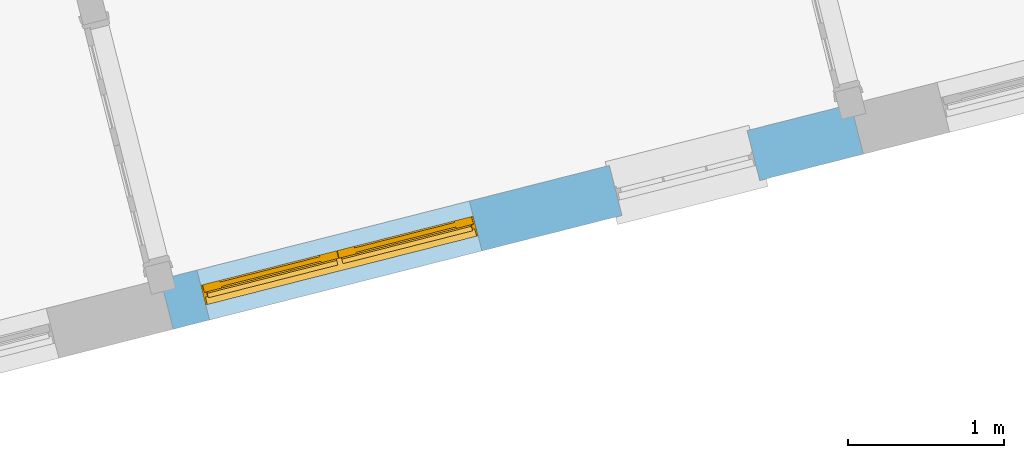
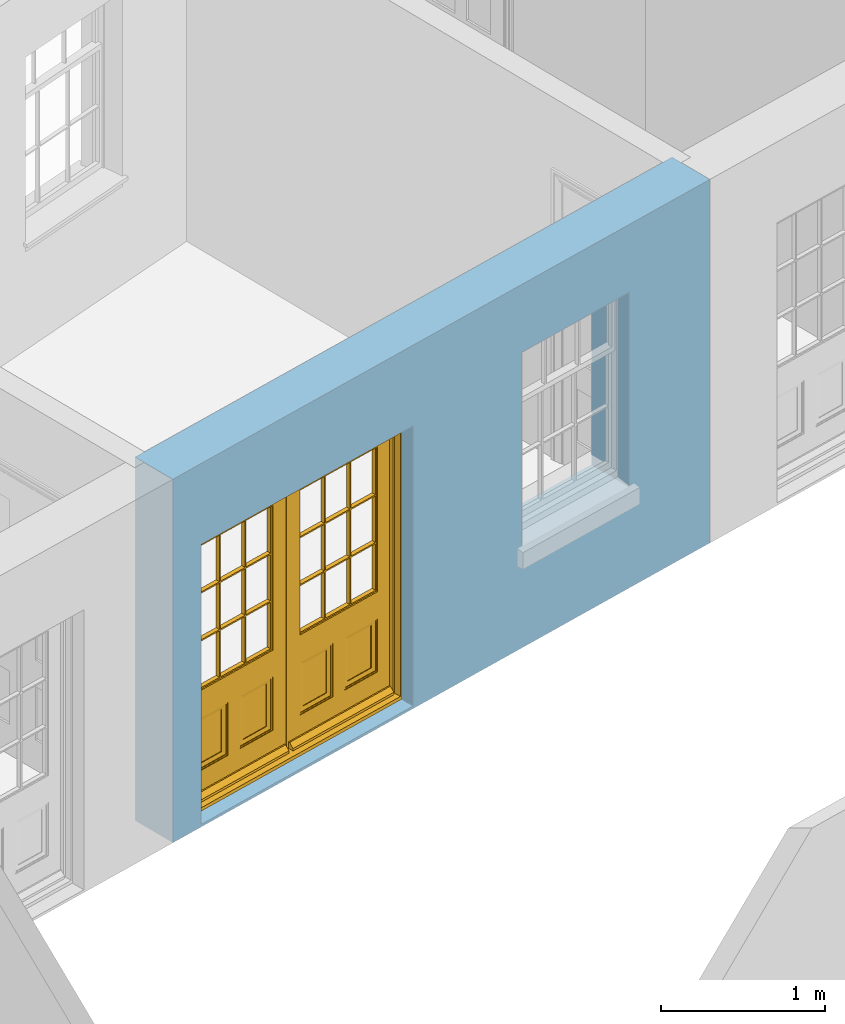
# One storey, part 3 of 15: 1 door, 2 openings, plus 1 element that does not belong to this part.
"""IFC2X3 building model written with IfcOpenShell, lengths in metres."""

from ifc_helpers import new_model, si_unit, frame, origin, place, context, subcontext, project, spatial, polyline, outline, extrude, faceted_brep, material, layer, layer_set, layer_usage, element, fill, save


model = new_model("IFC2X3")

# Units and contexts
model_context = context("Model", 3, world=origin())
body_context = subcontext(model_context, "Body", "Model", "MODEL_VIEW")
ifc_project = project(units=[si_unit("PLANEANGLEUNIT", "RADIAN"), si_unit("MASSUNIT", "GRAM", prefix="KILO"), si_unit("FORCEUNIT", "NEWTON", prefix="KILO"), si_unit("LENGTHUNIT", "METRE")], contexts=[model_context])

# Site, building, storey
site_placement = place(None, origin())
site = spatial("IfcSite", under=ifc_project, at=site_placement, CompositionType="ELEMENT")
building_placement = place(None, origin())
building = spatial("IfcBuilding", under=site, at=building_placement, Name="Building plot-13", CompositionType="ELEMENT")
storey_placement = place(None, frame((0.0, 0.0, 4.0)))
storey = spatial("IfcBuildingStorey", under=building, at=storey_placement, Name="Floor 0", CompositionType="ELEMENT", Elevation=4.0)

# Wall, openings, door
ifc_material = material(Name="Masonry")
ifc_layer = layer(ifc_material, 0.33, ventilated=False)
ifc_layer_set = layer_set([ifc_layer], Name="My Wall")
ifc_layer_usage = layer_usage(ifc_layer_set, "AXIS2", "NEGATIVE", 0.08)
wall_placement = place(storey_placement, origin())
wall = element("IfcWallStandardCase", 1, at=wall_placement, inside=storey, material=ifc_layer_usage, Name="exterior", context=body_context, shape_type="SweptSolid", body=[
    extrude(outline(polyline([(66.7491610907744, 43.8925759474061), (66.8302893451402, 43.5727037755256), (71.2509007169492, 44.6938906600119), (71.1697724625834, 45.0137628318924), (66.7491610907744, 43.8925759474061)])), origin(), (0.0, 0.0, 1.0), 2.7),
])
opening_1_placement = place(storey_placement, frame((0.0, 0.0, 0.0199999999999996)))
opening_1 = element("IfcOpeningElement", 2, at=opening_1_placement, cuts=wall, Name="Opening", ObjectType="Opening", context=body_context, shape_type="SweptSolid", body=[
    extrude(outline(polyline([(67.0630635375092, 43.631741621104), (68.8078208386756, 44.0742593721904), (68.7266925843098, 44.3941315440709), (66.9819352831434, 43.9516137929845), (67.0630635375092, 43.631741621104)])), origin(), (0.0, 0.0, 1.0), 2.08),
])
opening_2_placement = place(storey_placement, frame((0.0, 0.0, 0.75)))
element("IfcOpeningElement", 3, at=opening_2_placement, cuts=wall, Name="Opening", ObjectType="Opening", context=body_context, shape_type="SweptSolid", body=[
    extrude(outline(polyline([(69.7047120006465, 44.3017352851435), (70.5867837473473, 44.5254525926372), (70.5056554929815, 44.8453247645177), (69.6235837462807, 44.621607457024), (69.7047120006465, 44.3017352851435)])), origin(), (0.0, 0.0, 1.0), 1.445),
])
door_placement = place(storey_placement, frame((67.0016027387473, 43.8740690240438, 0.0199999999999996), z_axis=(0.0, 0.0, 1.0), x_axis=(1.7447573011664, 0.442517751086321, 0.0)))
door = element("IfcDoor", 4, at=door_placement, inside=storey, Name="living outside door", OverallHeight=2.08, OverallWidth=1.8, context=body_context, shape_type="Brep", held_by="IfcProductRepresentation", body=[
    faceted_brep([(0.545, -0.055, 0.265), (0.745, -0.055, 0.265), (0.745, -0.05, 0.265), (0.545, -0.05, 0.265), (0.745, -0.05, 0.58), (0.545, -0.05, 0.58), (0.545, -0.055, 0.58), (0.515, -0.06, 0.235), (0.775, -0.06, 0.235), (0.745, -0.055, 0.58), (0.515, -0.06, 0.61), (0.515, -0.065, 0.235), (0.775, -0.065, 0.235), (0.775, -0.06, 0.61), (0.515, -0.065, 0.61), (0.785, -0.065, 0.225), (0.505, -0.065, 0.225), (0.775, -0.065, 0.61), (0.505, -0.065, 0.62), (0.785, -0.065, 0.62), (0.505, -0.07, 0.225), (0.785, -0.07, 0.225), (0.505, -0.07, 0.62), (0.785, -0.07, 0.62), (0.883, -0.07, 0.075), (0.898, -0.07, 0.075), (0.405, -0.07, 0.62), (0.405, -0.07, 0.225), (0.027, -0.07, 0.075), (0.785, -0.07, 0.82), (0.125, -0.07, 0.82), (0.405, -0.065, 0.62), (0.405, -0.065, 0.225), (0.898, -0.07, 2.068), (0.027, -0.08, 0.075), (0.883, -0.08, 0.075), (0.125, -0.07, 0.225), (0.012, -0.07, 0.075), (0.785, -0.06, 0.82), (0.125, -0.06, 0.82), (0.125, -0.07, 0.62), (0.125, -0.065, 0.62), (0.395, -0.065, 0.61), (0.395, -0.065, 0.235), (0.125, -0.065, 0.225), (0.785, -0.07, 1.895), (0.027, -0.11, 0.045), (0.883, -0.11, 0.045), (0.558333, -0.06, 0.83), (0.351667, -0.06, 0.83), (0.125, -0.07, 1.895), (0.125, -0.06, 1.895), (0.785, -0.06, 1.895), (0.012, -0.07, 2.068), (0.135, -0.065, 0.61), (0.395, -0.06, 0.61), (0.395, -0.06, 0.235), (0.135, -0.065, 0.235), (0.027, -0.11, 0.027), (0.883, -0.11, 0.027), (0.568333, -0.06, 0.83), (0.558333, -0.03, 0.83), (0.351667, -0.03, 0.83), (0.341667, -0.06, 0.83), (0.135, -0.06, 1.185), (0.135, -0.06, 1.53), (0.775, -0.06, 1.53), (0.775, -0.06, 1.185), (0.135, -0.06, 0.61), (0.365, -0.055, 0.58), (0.365, -0.055, 0.265), (0.135, -0.06, 0.235), (0.568333, -0.06, 1.175), (0.558333, -0.06, 1.175), (0.775, -0.06, 0.83), (0.558333, -0.03, 1.175), (0.785, -0.03, 0.82), (0.125, -0.03, 0.82), (0.351667, -0.03, 1.175), (0.351667, -0.06, 1.175), (0.341667, -0.06, 1.175), (0.135, -0.06, 0.83), (0.135, -0.06, 1.175), (0.135, -0.03, 1.185), (0.135, -0.03, 1.53), (0.135, -0.06, 1.54), (0.351667, -0.06, 1.885), (0.558333, -0.06, 1.885), (0.775, -0.03, 1.53), (0.775, -0.03, 1.185), (0.775, -0.06, 1.175), (0.775, -0.06, 1.54), (0.165, -0.055, 0.58), (0.365, -0.05, 0.58), (0.365, -0.05, 0.265), (0.165, -0.055, 0.265), (0.568333, -0.03, 0.83), (0.568333, -0.03, 1.175), (0.568333, -0.06, 1.185), (0.558333, -0.06, 1.185), (0.775, -0.03, 0.83), (0.785, -0.02, 0.82), (0.125, -0.02, 0.82), (0.341667, -0.03, 0.83), (0.341667, -0.03, 1.175), (0.351667, -0.06, 1.185), (0.341667, -0.06, 1.185), (0.135, -0.03, 0.83), (0.341667, -0.03, 1.185), (0.125, -0.03, 1.895), (0.341667, -0.03, 1.53), (0.341667, -0.06, 1.53), (0.135, -0.06, 1.885), (0.341667, -0.06, 1.54), (0.341667, -0.06, 1.885), (0.558333, -0.03, 1.885), (0.351667, -0.03, 1.885), (0.568333, -0.06, 1.885), (0.785, -0.03, 1.895), (0.568333, -0.03, 1.185), (0.568333, -0.06, 1.53), (0.568333, -0.03, 1.53), (0.568333, -0.06, 1.54), (0.775, -0.06, 1.885), (0.165, -0.05, 0.58), (0.165, -0.05, 0.265), (0.775, -0.03, 1.175), (0.558333, -0.06, 1.53), (0.351667, -0.03, 1.185), (0.558333, -0.03, 1.185), (0.505, -0.02, 0.62), (0.405, -0.02, 0.62), (0.125, -0.02, 1.895), (0.785, -0.02, 1.895), (0.351667, -0.06, 1.53), (0.135, -0.03, 1.175), (0.135, -0.03, 1.54), (0.341667, -0.03, 1.54), (0.135, -0.03, 1.885), (0.351667, -0.06, 1.54), (0.558333, -0.03, 1.54), (0.558333, -0.06, 1.54), (0.351667, -0.03, 1.54), (0.775, -0.03, 1.54), (0.568333, -0.03, 1.54), (0.775, -0.03, 1.885), (0.558333, -0.03, 1.53), (0.405, -0.02, 0.225), (0.505, -0.02, 0.225), (0.125, -0.02, 0.62), (0.785, -0.02, 0.62), (0.012, -0.02, 2.068), (0.898, -0.02, 2.068), (0.351667, -0.03, 1.53), (0.341667, -0.03, 1.885), (0.568333, -0.03, 1.885), (0.405, -0.025, 0.225), (0.405, -0.025, 0.62), (0.505, -0.025, 0.62), (0.505, -0.025, 0.225), (0.898, -0.02, 0.027), (0.012, -0.02, 0.027), (0.125, -0.025, 0.62), (0.785, -0.025, 0.62), (0.395, -0.025, 0.235), (0.395, -0.025, 0.61), (0.125, -0.02, 0.225), (0.125, -0.025, 0.225), (0.515, -0.025, 0.61), (0.515, -0.025, 0.235), (0.785, -0.02, 0.225), (0.785, -0.025, 0.225), (0.135, -0.025, 0.61), (0.775, -0.025, 0.61), (0.135, -0.025, 0.235), (0.395, -0.03, 0.235), (0.395, -0.03, 0.61), (0.515, -0.03, 0.61), (0.515, -0.03, 0.235), (0.775, -0.025, 0.235), (0.135, -0.03, 0.61), (0.775, -0.03, 0.61), (0.135, -0.03, 0.235), (0.365, -0.035, 0.265), (0.365, -0.035, 0.58), (0.545, -0.035, 0.58), (0.545, -0.035, 0.265), (0.775, -0.03, 0.235), (0.165, -0.035, 0.58), (0.745, -0.035, 0.58), (0.165, -0.035, 0.265), (0.365, -0.04, 0.58), (0.365, -0.04, 0.265), (0.545, -0.04, 0.58), (0.545, -0.04, 0.265), (0.745, -0.035, 0.265), (0.165, -0.04, 0.58), (0.745, -0.04, 0.58), (0.165, -0.04, 0.265), (0.745, -0.04, 0.265), (1.775, -0.072, 0.025), (0.025, -0.072, 0.025), (0.025, -0.1, 0.025), (1.775, -0.1, 0.025), (1.79, -0.02, 0.025), (0.01, -0.02, 0.025), (1.79, -0.072, 0.025), (1.8, -0.02, 0.0), (0.0, -0.02, 0.0), (0.01, -0.072, 0.025), (1.79, -0.072, 2.07), (1.79, -0.02, 2.07), (1.775, -0.072, 2.055), (1.8, -0.02, 2.08), (0.01, -0.02, 2.07), (0.0, -0.02, 2.08), (0.01, -0.072, 2.07), (0.025, -0.072, 2.055), (0.0, -0.15, 2.08), (1.8, -0.15, 2.08), (0.01, -0.15, 2.07), (1.79, -0.15, 2.07), (0.01, -0.1, 2.07), (1.79, -0.1, 2.07), (0.0, -0.15, 0.0), (1.8, -0.15, 0.0), (0.01, -0.15, 0.025), (1.79, -0.15, 0.025), (0.01, -0.1, 0.025), (0.025, -0.1, 2.055), (1.79, -0.1, 0.025), (1.775, -0.1, 2.055), (0.898, -0.07, 0.027), (0.012, -0.07, 0.027), (0.883, -0.07, 0.027), (0.027, -0.07, 0.027), (1.435, -0.055, 0.265), (1.635, -0.055, 0.265), (1.635, -0.05, 0.265), (1.435, -0.05, 0.265), (1.635, -0.05, 0.58), (1.435, -0.05, 0.58), (1.435, -0.055, 0.58), (1.405, -0.06, 0.235), (1.665, -0.06, 0.235), (1.635, -0.055, 0.58), (1.405, -0.06, 0.61), (1.405, -0.065, 0.235), (1.665, -0.065, 0.235), (1.665, -0.06, 0.61), (1.405, -0.065, 0.61), (1.675, -0.065, 0.225), (1.395, -0.065, 0.225), (1.665, -0.065, 0.61), (1.395, -0.065, 0.62), (1.675, -0.065, 0.62), (1.395, -0.07, 0.225), (1.675, -0.07, 0.225), (1.395, -0.07, 0.62), (1.675, -0.07, 0.62), (1.773, -0.07, 0.075), (1.788, -0.07, 0.075), (1.295, -0.07, 0.62), (1.295, -0.07, 0.225), (0.917, -0.07, 0.075), (1.675, -0.07, 0.82), (1.015, -0.07, 0.82), (1.295, -0.065, 0.62), (1.295, -0.065, 0.225), (1.788, -0.07, 2.068), (0.917, -0.08, 0.075), (1.773, -0.08, 0.075), (1.015, -0.07, 0.225), (0.902, -0.07, 0.075), (1.675, -0.06, 0.82), (1.015, -0.06, 0.82), (1.015, -0.07, 0.62), (1.015, -0.065, 0.62), (1.285, -0.065, 0.61), (1.285, -0.065, 0.235), (1.015, -0.065, 0.225), (1.675, -0.07, 1.895), (0.917, -0.11, 0.045), (1.773, -0.11, 0.045), (1.448333, -0.06, 0.83), (1.241667, -0.06, 0.83), (1.015, -0.07, 1.895), (1.015, -0.06, 1.895), (1.675, -0.06, 1.895), (0.902, -0.07, 2.068), (1.025, -0.065, 0.61), (1.285, -0.06, 0.61), (1.285, -0.06, 0.235), (1.025, -0.065, 0.235), (0.917, -0.11, 0.027), (1.773, -0.11, 0.027), (1.458333, -0.06, 0.83), (1.448333, -0.03, 0.83), (1.241667, -0.03, 0.83), (1.231667, -0.06, 0.83), (1.025, -0.06, 1.185), (1.025, -0.06, 1.53), (1.665, -0.06, 1.53), (1.665, -0.06, 1.185), (1.025, -0.06, 0.61), (1.255, -0.055, 0.58), (1.255, -0.055, 0.265), (1.025, -0.06, 0.235), (1.458333, -0.06, 1.175), (1.448333, -0.06, 1.175), (1.665, -0.06, 0.83), (1.448333, -0.03, 1.175), (1.675, -0.03, 0.82), (1.015, -0.03, 0.82), (1.241667, -0.03, 1.175), (1.241667, -0.06, 1.175), (1.231667, -0.06, 1.175), (1.025, -0.06, 0.83), (1.025, -0.06, 1.175), (1.025, -0.03, 1.185), (1.025, -0.03, 1.53), (1.025, -0.06, 1.54), (1.241667, -0.06, 1.885), (1.448333, -0.06, 1.885), (1.665, -0.03, 1.53), (1.665, -0.03, 1.185), (1.665, -0.06, 1.175), (1.665, -0.06, 1.54), (1.055, -0.055, 0.58), (1.255, -0.05, 0.58), (1.255, -0.05, 0.265), (1.055, -0.055, 0.265), (1.458333, -0.03, 0.83), (1.458333, -0.03, 1.175), (1.458333, -0.06, 1.185), (1.448333, -0.06, 1.185), (1.665, -0.03, 0.83), (1.675, -0.02, 0.82), (1.015, -0.02, 0.82), (1.231667, -0.03, 0.83), (1.231667, -0.03, 1.175), (1.241667, -0.06, 1.185), (1.231667, -0.06, 1.185), (1.025, -0.03, 0.83), (1.231667, -0.03, 1.185), (1.015, -0.03, 1.895), (1.231667, -0.03, 1.53), (1.231667, -0.06, 1.53), (1.025, -0.06, 1.885), (1.231667, -0.06, 1.54), (1.231667, -0.06, 1.885), (1.448333, -0.03, 1.885), (1.241667, -0.03, 1.885), (1.458333, -0.06, 1.885), (1.675, -0.03, 1.895), (1.458333, -0.03, 1.185), (1.458333, -0.06, 1.53), (1.458333, -0.03, 1.53), (1.458333, -0.06, 1.54), (1.665, -0.06, 1.885), (1.055, -0.05, 0.58), (1.055, -0.05, 0.265), (1.665, -0.03, 1.175), (1.448333, -0.06, 1.53), (1.241667, -0.03, 1.185), (1.448333, -0.03, 1.185), (1.395, -0.02, 0.62), (1.295, -0.02, 0.62), (1.015, -0.02, 1.895), (1.675, -0.02, 1.895), (1.241667, -0.06, 1.53), (1.025, -0.03, 1.175), (1.025, -0.03, 1.54), (1.231667, -0.03, 1.54), (1.025, -0.03, 1.885), (1.241667, -0.06, 1.54), (1.448333, -0.03, 1.54), (1.448333, -0.06, 1.54), (1.241667, -0.03, 1.54), (1.665, -0.03, 1.54), (1.458333, -0.03, 1.54), (1.665, -0.03, 1.885), (1.448333, -0.03, 1.53), (1.295, -0.02, 0.225), (1.395, -0.02, 0.225), (1.015, -0.02, 0.62), (1.675, -0.02, 0.62), (0.902, -0.02, 2.068), (1.788, -0.02, 2.068), (1.241667, -0.03, 1.53), (1.231667, -0.03, 1.885), (1.458333, -0.03, 1.885), (1.295, -0.025, 0.225), (1.295, -0.025, 0.62), (1.395, -0.025, 0.62), (1.395, -0.025, 0.225), (1.788, -0.02, 0.027), (0.902, -0.02, 0.027), (1.015, -0.025, 0.62), (1.675, -0.025, 0.62), (1.285, -0.025, 0.235), (1.285, -0.025, 0.61), (1.015, -0.02, 0.225), (1.015, -0.025, 0.225), (1.405, -0.025, 0.61), (1.405, -0.025, 0.235), (1.675, -0.02, 0.225), (1.675, -0.025, 0.225), (1.025, -0.025, 0.61), (1.665, -0.025, 0.61), (1.025, -0.025, 0.235), (1.285, -0.03, 0.235), (1.285, -0.03, 0.61), (1.405, -0.03, 0.61), (1.405, -0.03, 0.235), (1.665, -0.025, 0.235), (1.025, -0.03, 0.61), (1.665, -0.03, 0.61), (1.025, -0.03, 0.235), (1.255, -0.035, 0.265), (1.255, -0.035, 0.58), (1.435, -0.035, 0.58), (1.435, -0.035, 0.265), (1.665, -0.03, 0.235), (1.055, -0.035, 0.58), (1.635, -0.035, 0.58), (1.055, -0.035, 0.265), (1.255, -0.04, 0.58), (1.255, -0.04, 0.265), (1.435, -0.04, 0.58), (1.435, -0.04, 0.265), (1.635, -0.035, 0.265), (1.055, -0.04, 0.58), (1.635, -0.04, 0.58), (1.055, -0.04, 0.265), (1.635, -0.04, 0.265), (1.788, -0.07, 0.027), (0.902, -0.07, 0.027), (1.773, -0.07, 0.027), (0.917, -0.07, 0.027)], [[[0, 1, 2, 3]], [[2, 4, 5, 3]], [[0, 3, 5, 6]], [[1, 0, 7, 8]], [[9, 4, 2, 1]], [[9, 6, 5, 4]], [[0, 6, 10, 7]], [[8, 7, 11, 12]], [[8, 13, 9, 1]], [[13, 10, 6, 9]], [[7, 10, 14, 11]], [[15, 12, 11, 16]], [[12, 17, 13, 8]], [[17, 14, 10, 13]], [[18, 16, 11, 14]], [[15, 19, 17, 12]], [[15, 16, 20, 21]], [[14, 17, 19, 18]], [[16, 18, 22, 20]], [[21, 23, 19, 15]], [[24, 25, 21, 20]], [[23, 22, 18, 19]], [[20, 22, 26, 27]], [[23, 21, 25]], [[28, 24, 20, 27]], [[22, 23, 29]], [[29, 30, 26, 22]], [[27, 26, 31, 32]], [[23, 25, 33, 29]], [[34, 35, 24, 28]], [[28, 27, 36, 37]], [[38, 39, 30, 29]], [[26, 30, 40]], [[26, 40, 41, 31]], [[42, 43, 32, 31]], [[32, 44, 36, 27]], [[33, 45, 29]], [[46, 47, 35, 34]], [[36, 40, 37]], [[39, 38, 48, 49]], [[50, 30, 39, 51]], [[29, 45, 52, 38]], [[53, 37, 40, 30]], [[44, 41, 40, 36]], [[31, 41, 54, 42]], [[43, 42, 55, 56]], [[57, 44, 32, 43]], [[50, 45, 33, 53]], [[47, 46, 58, 59]], [[60, 48, 38]], [[49, 48, 61, 62]], [[49, 63, 39]], [[50, 53, 30]], [[51, 39, 64, 65]], [[45, 50, 51, 52]], [[66, 67, 38, 52]], [[57, 54, 41, 44]], [[42, 54, 68, 55]], [[56, 55, 69, 70]], [[56, 71, 57, 43]], [[60, 72, 73, 48]], [[60, 38, 74]], [[48, 73, 75, 61]], [[76, 77, 62, 61]], [[62, 78, 79, 49]], [[49, 79, 80, 63]], [[63, 81, 39]], [[82, 64, 39]], [[65, 64, 83, 84]], [[85, 51, 65]], [[52, 51, 86, 87]], [[88, 89, 67, 66]], [[90, 38, 67]], [[91, 66, 52]], [[71, 68, 54, 57]], [[55, 68, 92, 69]], [[69, 93, 94, 70]], [[70, 95, 71, 56]], [[96, 97, 72, 60]], [[73, 72, 98, 99]], [[74, 38, 90]], [[100, 96, 60, 74]], [[75, 73, 79, 78]], [[61, 75, 97, 96]], [[101, 102, 77, 76]], [[77, 103, 62]], [[96, 76, 61]], [[103, 104, 78, 62]], [[80, 79, 105, 106]], [[63, 80, 104, 103]], [[81, 63, 103, 107]], [[81, 82, 39]], [[106, 64, 82, 80]], [[106, 108, 83, 64]], [[84, 83, 77, 109]], [[110, 111, 65, 84]], [[112, 51, 85]], [[113, 85, 65, 111]], [[114, 86, 51]], [[115, 87, 86, 116]], [[117, 52, 87]], [[118, 76, 89, 88]], [[119, 98, 67, 89]], [[120, 121, 88, 66]], [[67, 98, 72, 90]], [[91, 122, 120, 66]], [[91, 52, 123]], [[95, 92, 68, 71]], [[69, 92, 124, 93]], [[94, 93, 124, 125]], [[94, 125, 95, 70]], [[72, 97, 126, 90]], [[127, 99, 98, 120]], [[99, 105, 79, 73]], [[74, 90, 126, 100]], [[96, 100, 76]], [[128, 129, 75, 78]], [[97, 75, 129, 119]], [[130, 131, 102, 101]], [[109, 77, 102, 132]], [[133, 101, 76, 118]], [[77, 107, 103]], [[78, 104, 108, 128]], [[111, 106, 105, 134]], [[104, 80, 82, 135]], [[107, 135, 82, 81]], [[110, 108, 106, 111]], [[104, 135, 83, 108]], [[83, 135, 77]], [[136, 84, 109]], [[110, 84, 136, 137]], [[114, 51, 112]], [[85, 136, 138, 112]], [[113, 137, 136, 85]], [[111, 134, 139, 113]], [[86, 114, 113, 139]], [[140, 141, 87, 115]], [[139, 142, 116, 86]], [[109, 118, 115, 116]], [[117, 123, 52]], [[117, 87, 141, 122]], [[126, 89, 76]], [[143, 118, 88]], [[120, 98, 119, 121]], [[119, 89, 126, 97]], [[144, 143, 88, 121]], [[144, 122, 91, 143]], [[127, 120, 122, 141]], [[143, 91, 123, 145]], [[124, 92, 95, 125]], [[146, 129, 99, 127]], [[99, 129, 128, 105]], [[100, 126, 76]], [[121, 119, 129, 146]], [[147, 131, 130, 148]], [[131, 149, 102]], [[130, 101, 150]], [[102, 151, 132]], [[118, 109, 132, 133]], [[101, 133, 152]], [[107, 77, 135]], [[153, 128, 108, 110]], [[134, 105, 128, 153]], [[109, 138, 136]], [[153, 110, 137, 142]], [[154, 114, 112, 138]], [[137, 113, 114, 154]], [[141, 139, 134, 127]], [[141, 140, 142, 139]], [[144, 140, 115, 155]], [[142, 137, 154, 116]], [[155, 115, 118]], [[116, 154, 109]], [[117, 155, 145, 123]], [[122, 144, 155, 117]], [[143, 145, 118]], [[121, 146, 140, 144]], [[146, 127, 134, 153]], [[156, 157, 131, 147]], [[148, 130, 158, 159]], [[148, 160, 161, 147]], [[157, 162, 149, 131]], [[161, 151, 102, 149]], [[101, 152, 160, 150]], [[163, 158, 130, 150]], [[151, 152, 133, 132]], [[154, 138, 109]], [[142, 140, 146, 153]], [[145, 155, 118]], [[157, 156, 164, 165]], [[147, 166, 167, 156]], [[168, 169, 159, 158]], [[170, 148, 159, 171]], [[148, 170, 160]], [[166, 147, 161]], [[172, 162, 157, 165]], [[166, 149, 162, 167]], [[166, 161, 149]], [[150, 160, 170]], [[163, 173, 168, 158]], [[171, 163, 150, 170]], [[174, 164, 156, 167]], [[175, 176, 165, 164]], [[169, 168, 177, 178]], [[171, 159, 169, 179]], [[167, 162, 172, 174]], [[176, 180, 172, 165]], [[179, 173, 163, 171]], [[181, 177, 168, 173]], [[164, 174, 182, 175]], [[183, 184, 176, 175]], [[178, 177, 185, 186]], [[179, 169, 178, 187]], [[174, 172, 180, 182]], [[184, 188, 180, 176]], [[187, 181, 173, 179]], [[189, 185, 177, 181]], [[175, 182, 190, 183]], [[191, 184, 183, 192]], [[185, 193, 194, 186]], [[187, 178, 186, 195]], [[182, 180, 188, 190]], [[191, 196, 188, 184]], [[195, 189, 181, 187]], [[197, 193, 185, 189]], [[183, 190, 198, 192]], [[198, 196, 191, 192]], [[194, 193, 197, 199]], [[195, 186, 194, 199]], [[188, 196, 198, 190]], [[197, 189, 195, 199]], [[200, 201, 202, 203]], [[201, 200, 204, 205]], [[206, 204, 200]], [[204, 207, 208, 205]], [[209, 201, 205]], [[210, 211, 204, 206]], [[206, 200, 212, 210]], [[211, 213, 207, 204]], [[214, 205, 208, 215]], [[216, 217, 201, 209]], [[205, 214, 216, 209]], [[216, 214, 211, 210]], [[210, 212, 217, 216]], [[214, 215, 213, 211]], [[218, 219, 213, 215]], [[219, 218, 220, 221]], [[221, 220, 222, 223]], [[215, 208, 224, 218]], [[225, 224, 208, 207]], [[224, 226, 220, 218]], [[224, 225, 227, 226]], [[219, 225, 207, 213]], [[228, 222, 220, 226]], [[219, 221, 227, 225]], [[226, 227, 203, 202]], [[202, 229, 222, 228]], [[228, 226, 202]], [[227, 221, 223, 230]], [[230, 203, 227]], [[217, 229, 202, 201]], [[231, 223, 222, 229]], [[230, 223, 231, 203]], [[231, 229, 217, 212]], [[212, 200, 203, 231]], [[33, 152, 151, 53]], [[25, 160, 152, 33]], [[161, 37, 53, 151]], [[232, 160, 25]], [[161, 233, 37]], [[160, 232, 234]], [[24, 234, 232, 25]], [[233, 161, 235]], [[37, 233, 235, 28]], [[161, 160, 234, 235]], [[35, 47, 234, 24]], [[28, 235, 46, 34]], [[58, 235, 234, 59]], [[59, 234, 47]], [[58, 46, 235]], [[236, 237, 238, 239]], [[238, 240, 241, 239]], [[236, 239, 241, 242]], [[237, 236, 243, 244]], [[245, 240, 238, 237]], [[245, 242, 241, 240]], [[236, 242, 246, 243]], [[244, 243, 247, 248]], [[244, 249, 245, 237]], [[249, 246, 242, 245]], [[243, 246, 250, 247]], [[251, 248, 247, 252]], [[248, 253, 249, 244]], [[253, 250, 246, 249]], [[254, 252, 247, 250]], [[251, 255, 253, 248]], [[251, 252, 256, 257]], [[250, 253, 255, 254]], [[252, 254, 258, 256]], [[257, 259, 255, 251]], [[260, 261, 257, 256]], [[259, 258, 254, 255]], [[256, 258, 262, 263]], [[259, 257, 261]], [[264, 260, 256, 263]], [[258, 259, 265]], [[265, 266, 262, 258]], [[263, 262, 267, 268]], [[259, 261, 269, 265]], [[270, 271, 260, 264]], [[264, 263, 272, 273]], [[274, 275, 266, 265]], [[262, 266, 276]], [[262, 276, 277, 267]], [[278, 279, 268, 267]], [[268, 280, 272, 263]], [[269, 281, 265]], [[282, 283, 271, 270]], [[272, 276, 273]], [[275, 274, 284, 285]], [[286, 266, 275, 287]], [[265, 281, 288, 274]], [[289, 273, 276, 266]], [[280, 277, 276, 272]], [[267, 277, 290, 278]], [[279, 278, 291, 292]], [[293, 280, 268, 279]], [[286, 281, 269, 289]], [[283, 282, 294, 295]], [[296, 284, 274]], [[285, 284, 297, 298]], [[285, 299, 275]], [[286, 289, 266]], [[287, 275, 300, 301]], [[281, 286, 287, 288]], [[302, 303, 274, 288]], [[293, 290, 277, 280]], [[278, 290, 304, 291]], [[292, 291, 305, 306]], [[292, 307, 293, 279]], [[296, 308, 309, 284]], [[296, 274, 310]], [[284, 309, 311, 297]], [[312, 313, 298, 297]], [[298, 314, 315, 285]], [[285, 315, 316, 299]], [[299, 317, 275]], [[318, 300, 275]], [[301, 300, 319, 320]], [[321, 287, 301]], [[288, 287, 322, 323]], [[324, 325, 303, 302]], [[326, 274, 303]], [[327, 302, 288]], [[307, 304, 290, 293]], [[291, 304, 328, 305]], [[305, 329, 330, 306]], [[306, 331, 307, 292]], [[332, 333, 308, 296]], [[309, 308, 334, 335]], [[310, 274, 326]], [[336, 332, 296, 310]], [[311, 309, 315, 314]], [[297, 311, 333, 332]], [[337, 338, 313, 312]], [[313, 339, 298]], [[332, 312, 297]], [[339, 340, 314, 298]], [[316, 315, 341, 342]], [[299, 316, 340, 339]], [[317, 299, 339, 343]], [[317, 318, 275]], [[342, 300, 318, 316]], [[342, 344, 319, 300]], [[320, 319, 313, 345]], [[346, 347, 301, 320]], [[348, 287, 321]], [[349, 321, 301, 347]], [[350, 322, 287]], [[351, 323, 322, 352]], [[353, 288, 323]], [[354, 312, 325, 324]], [[355, 334, 303, 325]], [[356, 357, 324, 302]], [[303, 334, 308, 326]], [[327, 358, 356, 302]], [[327, 288, 359]], [[331, 328, 304, 307]], [[305, 328, 360, 329]], [[330, 329, 360, 361]], [[330, 361, 331, 306]], [[308, 333, 362, 326]], [[363, 335, 334, 356]], [[335, 341, 315, 309]], [[310, 326, 362, 336]], [[332, 336, 312]], [[364, 365, 311, 314]], [[333, 311, 365, 355]], [[366, 367, 338, 337]], [[345, 313, 338, 368]], [[369, 337, 312, 354]], [[313, 343, 339]], [[314, 340, 344, 364]], [[347, 342, 341, 370]], [[340, 316, 318, 371]], [[343, 371, 318, 317]], [[346, 344, 342, 347]], [[340, 371, 319, 344]], [[319, 371, 313]], [[372, 320, 345]], [[346, 320, 372, 373]], [[350, 287, 348]], [[321, 372, 374, 348]], [[349, 373, 372, 321]], [[347, 370, 375, 349]], [[322, 350, 349, 375]], [[376, 377, 323, 351]], [[375, 378, 352, 322]], [[345, 354, 351, 352]], [[353, 359, 288]], [[353, 323, 377, 358]], [[362, 325, 312]], [[379, 354, 324]], [[356, 334, 355, 357]], [[355, 325, 362, 333]], [[380, 379, 324, 357]], [[380, 358, 327, 379]], [[363, 356, 358, 377]], [[379, 327, 359, 381]], [[360, 328, 331, 361]], [[382, 365, 335, 363]], [[335, 365, 364, 341]], [[336, 362, 312]], [[357, 355, 365, 382]], [[383, 367, 366, 384]], [[367, 385, 338]], [[366, 337, 386]], [[338, 387, 368]], [[354, 345, 368, 369]], [[337, 369, 388]], [[343, 313, 371]], [[389, 364, 344, 346]], [[370, 341, 364, 389]], [[345, 374, 372]], [[389, 346, 373, 378]], [[390, 350, 348, 374]], [[373, 349, 350, 390]], [[377, 375, 370, 363]], [[377, 376, 378, 375]], [[380, 376, 351, 391]], [[378, 373, 390, 352]], [[391, 351, 354]], [[352, 390, 345]], [[353, 391, 381, 359]], [[358, 380, 391, 353]], [[379, 381, 354]], [[357, 382, 376, 380]], [[382, 363, 370, 389]], [[392, 393, 367, 383]], [[384, 366, 394, 395]], [[384, 396, 397, 383]], [[393, 398, 385, 367]], [[397, 387, 338, 385]], [[337, 388, 396, 386]], [[399, 394, 366, 386]], [[387, 388, 369, 368]], [[390, 374, 345]], [[378, 376, 382, 389]], [[381, 391, 354]], [[393, 392, 400, 401]], [[383, 402, 403, 392]], [[404, 405, 395, 394]], [[406, 384, 395, 407]], [[384, 406, 396]], [[402, 383, 397]], [[408, 398, 393, 401]], [[402, 385, 398, 403]], [[402, 397, 385]], [[386, 396, 406]], [[399, 409, 404, 394]], [[407, 399, 386, 406]], [[410, 400, 392, 403]], [[411, 412, 401, 400]], [[405, 404, 413, 414]], [[407, 395, 405, 415]], [[403, 398, 408, 410]], [[412, 416, 408, 401]], [[415, 409, 399, 407]], [[417, 413, 404, 409]], [[400, 410, 418, 411]], [[419, 420, 412, 411]], [[414, 413, 421, 422]], [[415, 405, 414, 423]], [[410, 408, 416, 418]], [[420, 424, 416, 412]], [[423, 417, 409, 415]], [[425, 421, 413, 417]], [[411, 418, 426, 419]], [[427, 420, 419, 428]], [[421, 429, 430, 422]], [[423, 414, 422, 431]], [[418, 416, 424, 426]], [[427, 432, 424, 420]], [[431, 425, 417, 423]], [[433, 429, 421, 425]], [[419, 426, 434, 428]], [[434, 432, 427, 428]], [[430, 429, 433, 435]], [[431, 422, 430, 435]], [[424, 432, 434, 426]], [[433, 425, 431, 435]], [[269, 388, 387, 289]], [[261, 396, 388, 269]], [[397, 273, 289, 387]], [[436, 396, 261]], [[397, 437, 273]], [[396, 436, 438]], [[260, 438, 436, 261]], [[437, 397, 439]], [[273, 437, 439, 264]], [[397, 396, 438, 439]], [[271, 283, 438, 260]], [[264, 439, 282, 270]], [[294, 439, 438, 295]], [[295, 438, 283]], [[294, 282, 439]]]),
])
fill(opening_1, door)

save(model, "model.ifc")
